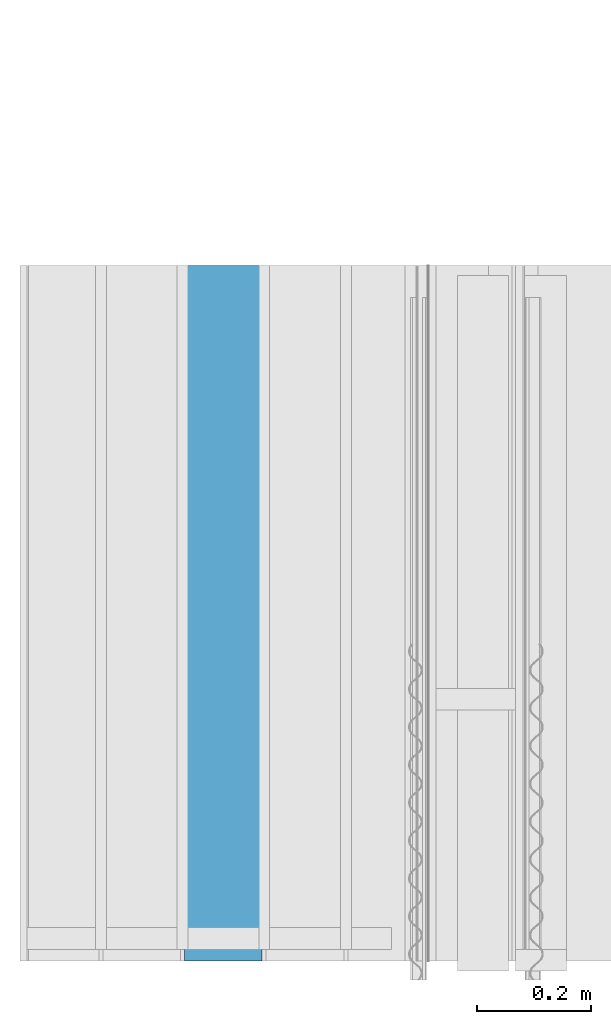
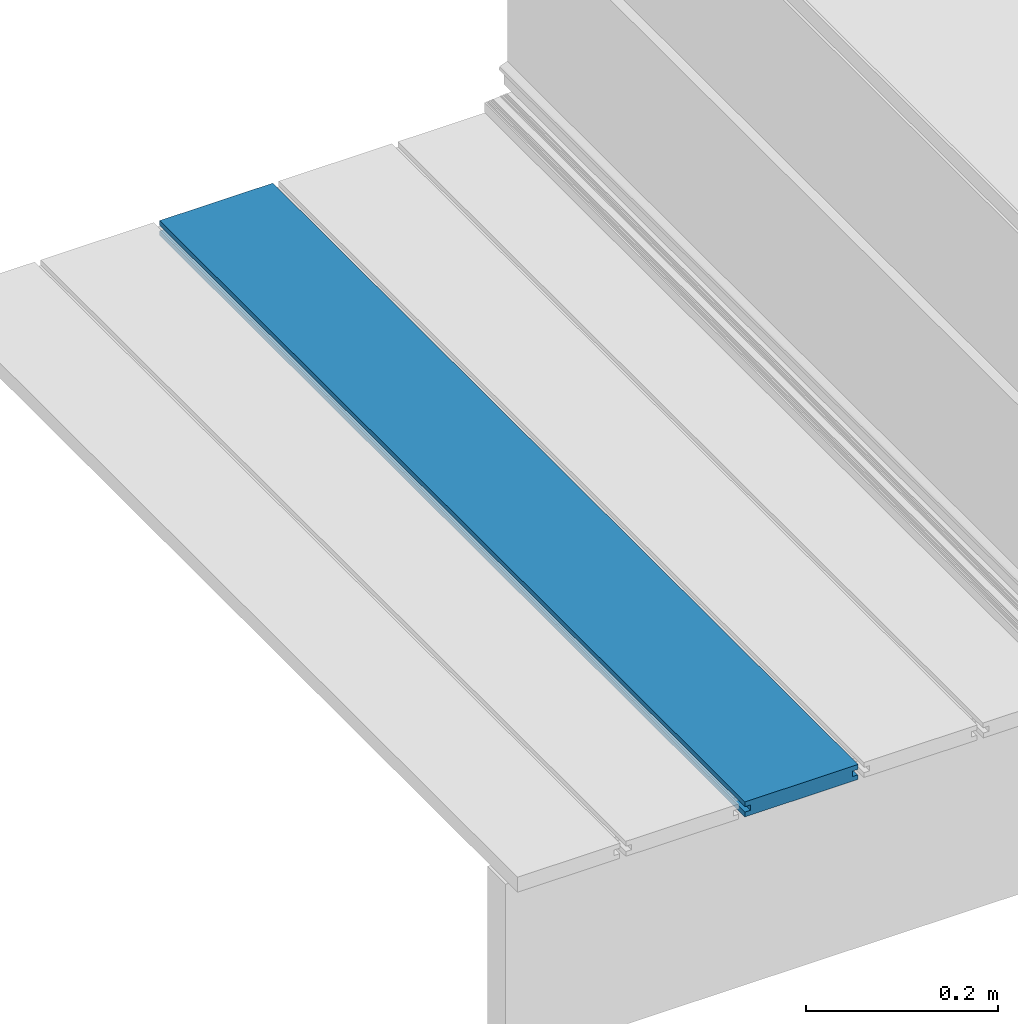
# One storey, part 6 of 33: 1 wall.
"""IFC4 building model written with IfcOpenShell, lengths in feet."""

from ifc_helpers import new_model, entity, si_unit, converted_unit, derived_unit, direction, frame, origin, place, context, subcontext, project, spatial, material, type_object, element, save


model = new_model("IFC4")

# Units and contexts
model_context = context("Model", 3, precision=0.0001, world=origin(), true_north=direction((6.12303176911189e-17, 1.0)))
body_context = subcontext(model_context, "Body", "Model", "MODEL_VIEW")
ifc_project = project(units=[converted_unit("LENGTHUNIT", "FOOT", entity("IfcRatioMeasure", 0.3048), si_unit("LENGTHUNIT", "METRE"), dimensions=[1, 0, 0, 0, 0, 0, 0]), converted_unit("AREAUNIT", "SQUARE FOOT", entity("IfcRatioMeasure", 0.09290304), si_unit("AREAUNIT", "SQUARE_METRE"), dimensions=[2, 0, 0, 0, 0, 0, 0]), converted_unit("VOLUMEUNIT", "CUBIC FOOT", entity("IfcRatioMeasure", 0.028316846592), si_unit("VOLUMEUNIT", "CUBIC_METRE"), dimensions=[3, 0, 0, 0, 0, 0, 0]), converted_unit("PLANEANGLEUNIT", "DEGREE", entity("IfcRatioMeasure", 0.0174532925199433), si_unit("PLANEANGLEUNIT", "RADIAN"), dimensions=[0, 0, 0, 0, 0, 0, 0]), si_unit("MASSUNIT", "GRAM", prefix="KILO"), derived_unit("MASSDENSITYUNIT", [(si_unit("MASSUNIT", "GRAM", prefix="KILO"), 1), (si_unit("LENGTHUNIT", "METRE"), -3)]), derived_unit("MOMENTOFINERTIAUNIT", [(si_unit("LENGTHUNIT", "METRE"), 4)]), si_unit("TIMEUNIT", "SECOND"), si_unit("FREQUENCYUNIT", "HERTZ"), si_unit("THERMODYNAMICTEMPERATUREUNIT", "DEGREE_CELSIUS"), derived_unit("THERMALTRANSMITTANCEUNIT", [(si_unit("MASSUNIT", "GRAM", prefix="KILO"), 1), (si_unit("THERMODYNAMICTEMPERATUREUNIT", "KELVIN"), -1), (si_unit("TIMEUNIT", "SECOND"), -3)]), derived_unit("VOLUMETRICFLOWRATEUNIT", [(si_unit("LENGTHUNIT", "METRE"), 3), (si_unit("TIMEUNIT", "SECOND"), -1)]), si_unit("ELECTRICCURRENTUNIT", "AMPERE"), si_unit("ELECTRICVOLTAGEUNIT", "VOLT"), si_unit("POWERUNIT", "WATT"), si_unit("FORCEUNIT", "NEWTON"), si_unit("ILLUMINANCEUNIT", "LUX"), si_unit("LUMINOUSFLUXUNIT", "LUMEN"), si_unit("LUMINOUSINTENSITYUNIT", "CANDELA"), derived_unit("USERDEFINED", [(si_unit("MASSUNIT", "GRAM", prefix="KILO"), -1), (si_unit("LENGTHUNIT", "METRE"), -2), (si_unit("TIMEUNIT", "SECOND"), 3), (si_unit("LUMINOUSFLUXUNIT", "LUMEN"), 1)]), derived_unit("LINEARVELOCITYUNIT", [(si_unit("LENGTHUNIT", "METRE"), 1), (si_unit("TIMEUNIT", "SECOND"), -1)]), si_unit("PRESSUREUNIT", "PASCAL"), derived_unit("USERDEFINED", [(si_unit("LENGTHUNIT", "METRE"), -2), (si_unit("MASSUNIT", "GRAM", prefix="KILO"), 1), (si_unit("TIMEUNIT", "SECOND"), -2)]), derived_unit("LINEARFORCEUNIT", [(si_unit("MASSUNIT", "GRAM", prefix="KILO"), 1), (si_unit("LENGTHUNIT", "METRE"), 1), (si_unit("TIMEUNIT", "SECOND"), -2), (si_unit("LENGTHUNIT", "METRE"), -1)]), derived_unit("PLANARFORCEUNIT", [(si_unit("MASSUNIT", "GRAM", prefix="KILO"), 1), (si_unit("LENGTHUNIT", "METRE"), 1), (si_unit("TIMEUNIT", "SECOND"), -2), (si_unit("LENGTHUNIT", "METRE"), -2)])], contexts=[model_context])

# Site, building, storey
site_placement = place(None, origin())
site = spatial("IfcSite", under=ifc_project, at=site_placement, CompositionType="ELEMENT")
building_placement = place(site_placement, origin())
building = spatial("IfcBuilding", under=site, at=building_placement, CompositionType="ELEMENT")
storey_placement = place(building_placement, frame((0.0, 0.0, 10.0)))
storey = spatial("IfcBuildingStorey", under=building, at=storey_placement, Name="2ND FLOOR", CompositionType="ELEMENT", Elevation=10.0000000000002)

# Wall
ifc_material = material(Name="COMPOSITE DECKING W/ HIDDEN FASTENERS", Category="Materials")
wall_type = type_object("IfcWallType", Name="Generic Models 646:Generic Models 1", PredefinedType="NOTDEFINED", material=ifc_material)
wall_placement = place(storey_placement, frame((1457.86428505908, 2.0, 0.618921366607442), z_axis=(0.0, 0.0, 1.0), x_axis=(0.0, 1.0, 0.0)))
cartesian_point_1 = entity("IfcCartesianPoint", [4.0, 0.0, 0.0])
vertex_point_1 = entity("IfcVertexPoint", cartesian_point_1)
cartesian_point_2 = entity("IfcCartesianPoint", [4.0, 0.0, 0.0198779960861497])
vertex_point_2 = entity("IfcVertexPoint", cartesian_point_2)
ifc_direction_1 = entity("IfcDirection", [0.0, 0.0, 1.0])
edge_curve_1 = entity("IfcEdgeCurve", vertex_point_1, vertex_point_2, entity("IfcTrimmedCurve", entity("IfcLine", cartesian_point_1, entity("IfcVector", ifc_direction_1, 1.0)), [cartesian_point_1], [cartesian_point_2], True, "CARTESIAN"), True)
cartesian_point_3 = entity("IfcCartesianPoint", [4.0, -0.0228400010810219, 0.0198779960861497])
vertex_point_3 = entity("IfcVertexPoint", cartesian_point_3)
ifc_direction_2 = entity("IfcDirection", [0.0, -1.0, 0.0])
edge_curve_2 = entity("IfcEdgeCurve", vertex_point_2, vertex_point_3, entity("IfcTrimmedCurve", entity("IfcLine", cartesian_point_2, entity("IfcVector", ifc_direction_2, 1.0)), [cartesian_point_2], [cartesian_point_3], True, "CARTESIAN"), True)
cartesian_point_4 = entity("IfcCartesianPoint", [4.0, -0.0228400010810219, 0.0422987663426539])
vertex_point_4 = entity("IfcVertexPoint", cartesian_point_4)
edge_curve_3 = entity("IfcEdgeCurve", vertex_point_3, vertex_point_4, entity("IfcTrimmedCurve", entity("IfcLine", cartesian_point_3, entity("IfcVector", ifc_direction_1, 1.0)), [cartesian_point_3], [cartesian_point_4], True, "CARTESIAN"), True)
cartesian_point_5 = entity("IfcCartesianPoint", [4.0, 0.0, 0.0422987663426539])
vertex_point_5 = entity("IfcVertexPoint", cartesian_point_5)
ifc_direction_3 = entity("IfcDirection", [0.0, 1.0, 0.0])
edge_curve_4 = entity("IfcEdgeCurve", vertex_point_4, vertex_point_5, entity("IfcTrimmedCurve", entity("IfcLine", cartesian_point_4, entity("IfcVector", ifc_direction_3, 1.0)), [cartesian_point_4], [cartesian_point_5], True, "CARTESIAN"), True)
cartesian_point_6 = entity("IfcCartesianPoint", [4.0, 0.0, 0.0625000000000018])
vertex_point_6 = entity("IfcVertexPoint", cartesian_point_6)
edge_curve_5 = entity("IfcEdgeCurve", vertex_point_5, vertex_point_6, entity("IfcTrimmedCurve", entity("IfcLine", cartesian_point_5, entity("IfcVector", ifc_direction_1, 1.0)), [cartesian_point_5], [cartesian_point_6], True, "CARTESIAN"), True)
cartesian_point_7 = entity("IfcCartesianPoint", [4.0, -0.446740923891639, 0.0625000000000568])
vertex_point_7 = entity("IfcVertexPoint", cartesian_point_7)
edge_curve_6 = entity("IfcEdgeCurve", vertex_point_6, vertex_point_7, entity("IfcTrimmedCurve", entity("IfcLine", cartesian_point_6, entity("IfcVector", ifc_direction_2, 1.0)), [cartesian_point_6], [cartesian_point_7], True, "CARTESIAN"), True)
cartesian_point_8 = entity("IfcCartesianPoint", [4.0, -0.446740923891639, 0.0422987663426539])
vertex_point_8 = entity("IfcVertexPoint", cartesian_point_8)
ifc_direction_4 = entity("IfcDirection", [0.0, 0.0, -1.0])
edge_curve_7 = entity("IfcEdgeCurve", vertex_point_7, vertex_point_8, entity("IfcTrimmedCurve", entity("IfcLine", cartesian_point_7, entity("IfcVector", ifc_direction_4, 1.0)), [cartesian_point_7], [cartesian_point_8], True, "CARTESIAN"), True)
cartesian_point_9 = entity("IfcCartesianPoint", [4.0, -0.423900922810844, 0.0422987663426539])
vertex_point_9 = entity("IfcVertexPoint", cartesian_point_9)
edge_curve_8 = entity("IfcEdgeCurve", vertex_point_8, vertex_point_9, entity("IfcTrimmedCurve", entity("IfcLine", cartesian_point_8, entity("IfcVector", ifc_direction_3, 1.0)), [cartesian_point_8], [cartesian_point_9], True, "CARTESIAN"), True)
cartesian_point_10 = entity("IfcCartesianPoint", [4.0, -0.423900922810844, 0.0198779960861497])
vertex_point_10 = entity("IfcVertexPoint", cartesian_point_10)
edge_curve_9 = entity("IfcEdgeCurve", vertex_point_9, vertex_point_10, entity("IfcTrimmedCurve", entity("IfcLine", cartesian_point_9, entity("IfcVector", ifc_direction_4, 1.0)), [cartesian_point_9], [cartesian_point_10], True, "CARTESIAN"), True)
cartesian_point_11 = entity("IfcCartesianPoint", [4.0, -0.445416170097133, 0.0198779960861497])
vertex_point_11 = entity("IfcVertexPoint", cartesian_point_11)
edge_curve_10 = entity("IfcEdgeCurve", vertex_point_10, vertex_point_11, entity("IfcTrimmedCurve", entity("IfcLine", cartesian_point_10, entity("IfcVector", ifc_direction_2, 1.0)), [cartesian_point_10], [cartesian_point_11], True, "CARTESIAN"), True)
cartesian_point_12 = entity("IfcCartesianPoint", [4.0, -0.445416170097133, 0.0])
vertex_point_12 = entity("IfcVertexPoint", cartesian_point_12)
edge_curve_11 = entity("IfcEdgeCurve", vertex_point_11, vertex_point_12, entity("IfcTrimmedCurve", entity("IfcLine", cartesian_point_11, entity("IfcVector", ifc_direction_4, 1.0)), [cartesian_point_11], [cartesian_point_12], True, "CARTESIAN"), True)
edge_curve_12 = entity("IfcEdgeCurve", vertex_point_12, vertex_point_1, entity("IfcTrimmedCurve", entity("IfcLine", cartesian_point_12, entity("IfcVector", ifc_direction_3, 1.0)), [cartesian_point_12], [cartesian_point_1], True, "CARTESIAN"), True)
ifc_direction_5 = entity("IfcDirection", [1.0, 0.0, 0.0])
cartesian_point_13 = entity("IfcCartesianPoint", [0.0, 0.0, 0.0])
vertex_point_13 = entity("IfcVertexPoint", cartesian_point_13)
cartesian_point_14 = entity("IfcCartesianPoint", [0.0, -0.445416170097133, 0.0])
vertex_point_14 = entity("IfcVertexPoint", cartesian_point_14)
edge_curve_13 = entity("IfcEdgeCurve", vertex_point_13, vertex_point_14, entity("IfcTrimmedCurve", entity("IfcLine", cartesian_point_13, entity("IfcVector", ifc_direction_2, 1.0)), [cartesian_point_13], [cartesian_point_14], True, "CARTESIAN"), True)
cartesian_point_15 = entity("IfcCartesianPoint", [0.0, -0.445416170097133, 0.0198779960861462])
vertex_point_15 = entity("IfcVertexPoint", cartesian_point_15)
edge_curve_14 = entity("IfcEdgeCurve", vertex_point_14, vertex_point_15, entity("IfcTrimmedCurve", entity("IfcLine", cartesian_point_14, entity("IfcVector", ifc_direction_1, 1.0)), [cartesian_point_14], [cartesian_point_15], True, "CARTESIAN"), True)
cartesian_point_16 = entity("IfcCartesianPoint", [0.0, -0.423900922810844, 0.0198779960861462])
vertex_point_16 = entity("IfcVertexPoint", cartesian_point_16)
edge_curve_15 = entity("IfcEdgeCurve", vertex_point_15, vertex_point_16, entity("IfcTrimmedCurve", entity("IfcLine", cartesian_point_15, entity("IfcVector", ifc_direction_3, 1.0)), [cartesian_point_15], [cartesian_point_16], True, "CARTESIAN"), True)
cartesian_point_17 = entity("IfcCartesianPoint", [0.0, -0.423900922810844, 0.0422987663426522])
vertex_point_17 = entity("IfcVertexPoint", cartesian_point_17)
edge_curve_16 = entity("IfcEdgeCurve", vertex_point_16, vertex_point_17, entity("IfcTrimmedCurve", entity("IfcLine", cartesian_point_16, entity("IfcVector", ifc_direction_1, 1.0)), [cartesian_point_16], [cartesian_point_17], True, "CARTESIAN"), True)
cartesian_point_18 = entity("IfcCartesianPoint", [0.0, -0.446740923891639, 0.0422987663426522])
vertex_point_18 = entity("IfcVertexPoint", cartesian_point_18)
edge_curve_17 = entity("IfcEdgeCurve", vertex_point_17, vertex_point_18, entity("IfcTrimmedCurve", entity("IfcLine", cartesian_point_17, entity("IfcVector", ifc_direction_2, 1.0)), [cartesian_point_17], [cartesian_point_18], True, "CARTESIAN"), True)
cartesian_point_19 = entity("IfcCartesianPoint", [0.0, -0.446740923891639, 0.0625000000000551])
vertex_point_19 = entity("IfcVertexPoint", cartesian_point_19)
edge_curve_18 = entity("IfcEdgeCurve", vertex_point_18, vertex_point_19, entity("IfcTrimmedCurve", entity("IfcLine", cartesian_point_18, entity("IfcVector", ifc_direction_1, 1.0)), [cartesian_point_18], [cartesian_point_19], True, "CARTESIAN"), True)
cartesian_point_20 = entity("IfcCartesianPoint", [0.0, 0.0, 0.0624999999999982])
vertex_point_20 = entity("IfcVertexPoint", cartesian_point_20)
edge_curve_19 = entity("IfcEdgeCurve", vertex_point_19, vertex_point_20, entity("IfcTrimmedCurve", entity("IfcLine", cartesian_point_19, entity("IfcVector", ifc_direction_3, 1.0)), [cartesian_point_19], [cartesian_point_20], True, "CARTESIAN"), True)
cartesian_point_21 = entity("IfcCartesianPoint", [0.0, 0.0, 0.0422987663426522])
vertex_point_21 = entity("IfcVertexPoint", cartesian_point_21)
edge_curve_20 = entity("IfcEdgeCurve", vertex_point_20, vertex_point_21, entity("IfcTrimmedCurve", entity("IfcLine", cartesian_point_20, entity("IfcVector", ifc_direction_4, 1.0)), [cartesian_point_20], [cartesian_point_21], True, "CARTESIAN"), True)
cartesian_point_22 = entity("IfcCartesianPoint", [0.0, -0.0228400010810219, 0.0422987663426522])
vertex_point_22 = entity("IfcVertexPoint", cartesian_point_22)
edge_curve_21 = entity("IfcEdgeCurve", vertex_point_21, vertex_point_22, entity("IfcTrimmedCurve", entity("IfcLine", cartesian_point_21, entity("IfcVector", ifc_direction_2, 1.0)), [cartesian_point_21], [cartesian_point_22], True, "CARTESIAN"), True)
cartesian_point_23 = entity("IfcCartesianPoint", [0.0, -0.0228400010810219, 0.0198779960861462])
vertex_point_23 = entity("IfcVertexPoint", cartesian_point_23)
edge_curve_22 = entity("IfcEdgeCurve", vertex_point_22, vertex_point_23, entity("IfcTrimmedCurve", entity("IfcLine", cartesian_point_22, entity("IfcVector", ifc_direction_4, 1.0)), [cartesian_point_22], [cartesian_point_23], True, "CARTESIAN"), True)
cartesian_point_24 = entity("IfcCartesianPoint", [0.0, 0.0, 0.0198779960861462])
vertex_point_24 = entity("IfcVertexPoint", cartesian_point_24)
edge_curve_23 = entity("IfcEdgeCurve", vertex_point_23, vertex_point_24, entity("IfcTrimmedCurve", entity("IfcLine", cartesian_point_23, entity("IfcVector", ifc_direction_3, 1.0)), [cartesian_point_23], [cartesian_point_24], True, "CARTESIAN"), True)
edge_curve_24 = entity("IfcEdgeCurve", vertex_point_24, vertex_point_13, entity("IfcTrimmedCurve", entity("IfcLine", cartesian_point_24, entity("IfcVector", ifc_direction_4, 1.0)), [cartesian_point_24], [cartesian_point_13], True, "CARTESIAN"), True)
ifc_direction_6 = entity("IfcDirection", [-1.0, 0.0, 0.0])
edge_curve_25 = entity("IfcEdgeCurve", vertex_point_24, vertex_point_2, entity("IfcTrimmedCurve", entity("IfcLine", cartesian_point_24, entity("IfcVector", ifc_direction_5, 1.0)), [cartesian_point_24], [cartesian_point_2], True, "CARTESIAN"), True)
edge_curve_26 = entity("IfcEdgeCurve", vertex_point_1, vertex_point_13, entity("IfcTrimmedCurve", entity("IfcLine", cartesian_point_13, entity("IfcVector", ifc_direction_6, 1.0)), [cartesian_point_1], [cartesian_point_13], True, "CARTESIAN"), True)
edge_curve_27 = entity("IfcEdgeCurve", vertex_point_19, vertex_point_7, entity("IfcTrimmedCurve", entity("IfcLine", cartesian_point_19, entity("IfcVector", ifc_direction_5, 1.0)), [cartesian_point_19], [cartesian_point_7], True, "CARTESIAN"), True)
edge_curve_28 = entity("IfcEdgeCurve", vertex_point_6, vertex_point_20, entity("IfcTrimmedCurve", entity("IfcLine", cartesian_point_20, entity("IfcVector", ifc_direction_6, 1.0)), [cartesian_point_6], [cartesian_point_20], True, "CARTESIAN"), True)
edge_curve_29 = entity("IfcEdgeCurve", vertex_point_18, vertex_point_8, entity("IfcTrimmedCurve", entity("IfcLine", cartesian_point_18, entity("IfcVector", ifc_direction_5, 1.0)), [cartesian_point_18], [cartesian_point_8], True, "CARTESIAN"), True)
edge_curve_30 = entity("IfcEdgeCurve", vertex_point_12, vertex_point_14, entity("IfcTrimmedCurve", entity("IfcLine", cartesian_point_14, entity("IfcVector", ifc_direction_6, 1.0)), [cartesian_point_12], [cartesian_point_14], True, "CARTESIAN"), True)
edge_curve_31 = entity("IfcEdgeCurve", vertex_point_5, vertex_point_21, entity("IfcTrimmedCurve", entity("IfcLine", cartesian_point_21, entity("IfcVector", ifc_direction_6, 1.0)), [cartesian_point_5], [cartesian_point_21], True, "CARTESIAN"), True)
edge_curve_32 = entity("IfcEdgeCurve", vertex_point_17, vertex_point_9, entity("IfcTrimmedCurve", entity("IfcLine", cartesian_point_17, entity("IfcVector", ifc_direction_5, 1.0)), [cartesian_point_17], [cartesian_point_9], True, "CARTESIAN"), True)
edge_curve_33 = entity("IfcEdgeCurve", vertex_point_16, vertex_point_10, entity("IfcTrimmedCurve", entity("IfcLine", cartesian_point_16, entity("IfcVector", ifc_direction_5, 1.0)), [cartesian_point_16], [cartesian_point_10], True, "CARTESIAN"), True)
edge_curve_34 = entity("IfcEdgeCurve", vertex_point_15, vertex_point_11, entity("IfcTrimmedCurve", entity("IfcLine", cartesian_point_15, entity("IfcVector", ifc_direction_5, 1.0)), [cartesian_point_15], [cartesian_point_11], True, "CARTESIAN"), True)
edge_curve_35 = entity("IfcEdgeCurve", vertex_point_23, vertex_point_3, entity("IfcTrimmedCurve", entity("IfcLine", cartesian_point_23, entity("IfcVector", ifc_direction_5, 1.0)), [cartesian_point_23], [cartesian_point_3], True, "CARTESIAN"), True)
edge_curve_36 = entity("IfcEdgeCurve", vertex_point_22, vertex_point_4, entity("IfcTrimmedCurve", entity("IfcLine", cartesian_point_22, entity("IfcVector", ifc_direction_5, 1.0)), [cartesian_point_22], [cartesian_point_4], True, "CARTESIAN"), True)
element("IfcWall", 1, at=wall_placement, inside=storey, type_object=wall_type, material=ifc_material, Name="Generic Models 646:Generic Models 1", ObjectType="Generic Models 646:Generic Models 1", PredefinedType="NOTDEFINED", context=body_context, shape_type="AdvancedBrep", body=[
    entity("IfcAdvancedBrep", entity("IfcClosedShell", [entity("IfcAdvancedFace", [entity("IfcFaceOuterBound", entity("IfcEdgeLoop", [entity("IfcOrientedEdge", None, None, edge_curve_1, True), entity("IfcOrientedEdge", None, None, edge_curve_2, True), entity("IfcOrientedEdge", None, None, edge_curve_3, True), entity("IfcOrientedEdge", None, None, edge_curve_4, True), entity("IfcOrientedEdge", None, None, edge_curve_5, True), entity("IfcOrientedEdge", None, None, edge_curve_6, True), entity("IfcOrientedEdge", None, None, edge_curve_7, True), entity("IfcOrientedEdge", None, None, edge_curve_8, True), entity("IfcOrientedEdge", None, None, edge_curve_9, True), entity("IfcOrientedEdge", None, None, edge_curve_10, True), entity("IfcOrientedEdge", None, None, edge_curve_11, True), entity("IfcOrientedEdge", None, None, edge_curve_12, True)]), True)], entity("IfcPlane", entity("IfcAxis2Placement3D", entity("IfcCartesianPoint", [4.0, 3.98642313864389, 0.0]), ifc_direction_5, ifc_direction_3)), True), entity("IfcAdvancedFace", [entity("IfcFaceOuterBound", entity("IfcEdgeLoop", [entity("IfcOrientedEdge", None, None, edge_curve_13, True), entity("IfcOrientedEdge", None, None, edge_curve_14, True), entity("IfcOrientedEdge", None, None, edge_curve_15, True), entity("IfcOrientedEdge", None, None, edge_curve_16, True), entity("IfcOrientedEdge", None, None, edge_curve_17, True), entity("IfcOrientedEdge", None, None, edge_curve_18, True), entity("IfcOrientedEdge", None, None, edge_curve_19, True), entity("IfcOrientedEdge", None, None, edge_curve_20, True), entity("IfcOrientedEdge", None, None, edge_curve_21, True), entity("IfcOrientedEdge", None, None, edge_curve_22, True), entity("IfcOrientedEdge", None, None, edge_curve_23, True), entity("IfcOrientedEdge", None, None, edge_curve_24, True)]), True)], entity("IfcPlane", entity("IfcAxis2Placement3D", entity("IfcCartesianPoint", [0.0, 3.98642313864389, 0.0]), ifc_direction_6, ifc_direction_2)), True), entity("IfcAdvancedFace", [entity("IfcFaceOuterBound", entity("IfcEdgeLoop", [entity("IfcOrientedEdge", None, None, edge_curve_24, False), entity("IfcOrientedEdge", None, None, edge_curve_25, True), entity("IfcOrientedEdge", None, None, edge_curve_1, False), entity("IfcOrientedEdge", None, None, edge_curve_26, True)]), True)], entity("IfcPlane", entity("IfcAxis2Placement3D", cartesian_point_24, ifc_direction_3, ifc_direction_5)), True), entity("IfcAdvancedFace", [entity("IfcFaceOuterBound", entity("IfcEdgeLoop", [entity("IfcOrientedEdge", None, None, edge_curve_19, False), entity("IfcOrientedEdge", None, None, edge_curve_27, True), entity("IfcOrientedEdge", None, None, edge_curve_6, False), entity("IfcOrientedEdge", None, None, edge_curve_28, True)]), True)], entity("IfcPlane", entity("IfcAxis2Placement3D", cartesian_point_19, ifc_direction_1, ifc_direction_5)), True), entity("IfcAdvancedFace", [entity("IfcFaceOuterBound", entity("IfcEdgeLoop", [entity("IfcOrientedEdge", None, None, edge_curve_18, False), entity("IfcOrientedEdge", None, None, edge_curve_29, True), entity("IfcOrientedEdge", None, None, edge_curve_7, False), entity("IfcOrientedEdge", None, None, edge_curve_27, False)]), True)], entity("IfcPlane", entity("IfcAxis2Placement3D", cartesian_point_18, ifc_direction_2, ifc_direction_5)), True), entity("IfcAdvancedFace", [entity("IfcFaceOuterBound", entity("IfcEdgeLoop", [entity("IfcOrientedEdge", None, None, edge_curve_13, False), entity("IfcOrientedEdge", None, None, edge_curve_26, False), entity("IfcOrientedEdge", None, None, edge_curve_12, False), entity("IfcOrientedEdge", None, None, edge_curve_30, True)]), True)], entity("IfcPlane", entity("IfcAxis2Placement3D", cartesian_point_13, ifc_direction_4, ifc_direction_5)), True), entity("IfcAdvancedFace", [entity("IfcFaceOuterBound", entity("IfcEdgeLoop", [entity("IfcOrientedEdge", None, None, edge_curve_20, False), entity("IfcOrientedEdge", None, None, edge_curve_28, False), entity("IfcOrientedEdge", None, None, edge_curve_5, False), entity("IfcOrientedEdge", None, None, edge_curve_31, True)]), True)], entity("IfcPlane", entity("IfcAxis2Placement3D", cartesian_point_20, ifc_direction_3, ifc_direction_5)), True), entity("IfcAdvancedFace", [entity("IfcFaceOuterBound", entity("IfcEdgeLoop", [entity("IfcOrientedEdge", None, None, edge_curve_17, False), entity("IfcOrientedEdge", None, None, edge_curve_32, True), entity("IfcOrientedEdge", None, None, edge_curve_8, False), entity("IfcOrientedEdge", None, None, edge_curve_29, False)]), True)], entity("IfcPlane", entity("IfcAxis2Placement3D", cartesian_point_17, ifc_direction_4, ifc_direction_5)), True), entity("IfcAdvancedFace", [entity("IfcFaceOuterBound", entity("IfcEdgeLoop", [entity("IfcOrientedEdge", None, None, edge_curve_16, False), entity("IfcOrientedEdge", None, None, edge_curve_33, True), entity("IfcOrientedEdge", None, None, edge_curve_9, False), entity("IfcOrientedEdge", None, None, edge_curve_32, False)]), True)], entity("IfcPlane", entity("IfcAxis2Placement3D", cartesian_point_16, ifc_direction_2, ifc_direction_5)), True), entity("IfcAdvancedFace", [entity("IfcFaceOuterBound", entity("IfcEdgeLoop", [entity("IfcOrientedEdge", None, None, edge_curve_15, False), entity("IfcOrientedEdge", None, None, edge_curve_34, True), entity("IfcOrientedEdge", None, None, edge_curve_10, False), entity("IfcOrientedEdge", None, None, edge_curve_33, False)]), True)], entity("IfcPlane", entity("IfcAxis2Placement3D", cartesian_point_15, ifc_direction_1, ifc_direction_5)), True), entity("IfcAdvancedFace", [entity("IfcFaceOuterBound", entity("IfcEdgeLoop", [entity("IfcOrientedEdge", None, None, edge_curve_14, False), entity("IfcOrientedEdge", None, None, edge_curve_30, False), entity("IfcOrientedEdge", None, None, edge_curve_11, False), entity("IfcOrientedEdge", None, None, edge_curve_34, False)]), True)], entity("IfcPlane", entity("IfcAxis2Placement3D", cartesian_point_14, ifc_direction_2, ifc_direction_5)), True), entity("IfcAdvancedFace", [entity("IfcFaceOuterBound", entity("IfcEdgeLoop", [entity("IfcOrientedEdge", None, None, edge_curve_23, False), entity("IfcOrientedEdge", None, None, edge_curve_35, True), entity("IfcOrientedEdge", None, None, edge_curve_2, False), entity("IfcOrientedEdge", None, None, edge_curve_25, False)]), True)], entity("IfcPlane", entity("IfcAxis2Placement3D", cartesian_point_23, ifc_direction_1, ifc_direction_5)), True), entity("IfcAdvancedFace", [entity("IfcFaceOuterBound", entity("IfcEdgeLoop", [entity("IfcOrientedEdge", None, None, edge_curve_22, False), entity("IfcOrientedEdge", None, None, edge_curve_36, True), entity("IfcOrientedEdge", None, None, edge_curve_3, False), entity("IfcOrientedEdge", None, None, edge_curve_35, False)]), True)], entity("IfcPlane", entity("IfcAxis2Placement3D", cartesian_point_22, ifc_direction_3, ifc_direction_5)), True), entity("IfcAdvancedFace", [entity("IfcFaceOuterBound", entity("IfcEdgeLoop", [entity("IfcOrientedEdge", None, None, edge_curve_21, False), entity("IfcOrientedEdge", None, None, edge_curve_31, False), entity("IfcOrientedEdge", None, None, edge_curve_4, False), entity("IfcOrientedEdge", None, None, edge_curve_36, False)]), True)], entity("IfcPlane", entity("IfcAxis2Placement3D", cartesian_point_21, ifc_direction_4, ifc_direction_5)), True)])),
])

save(model, "model.ifc")
